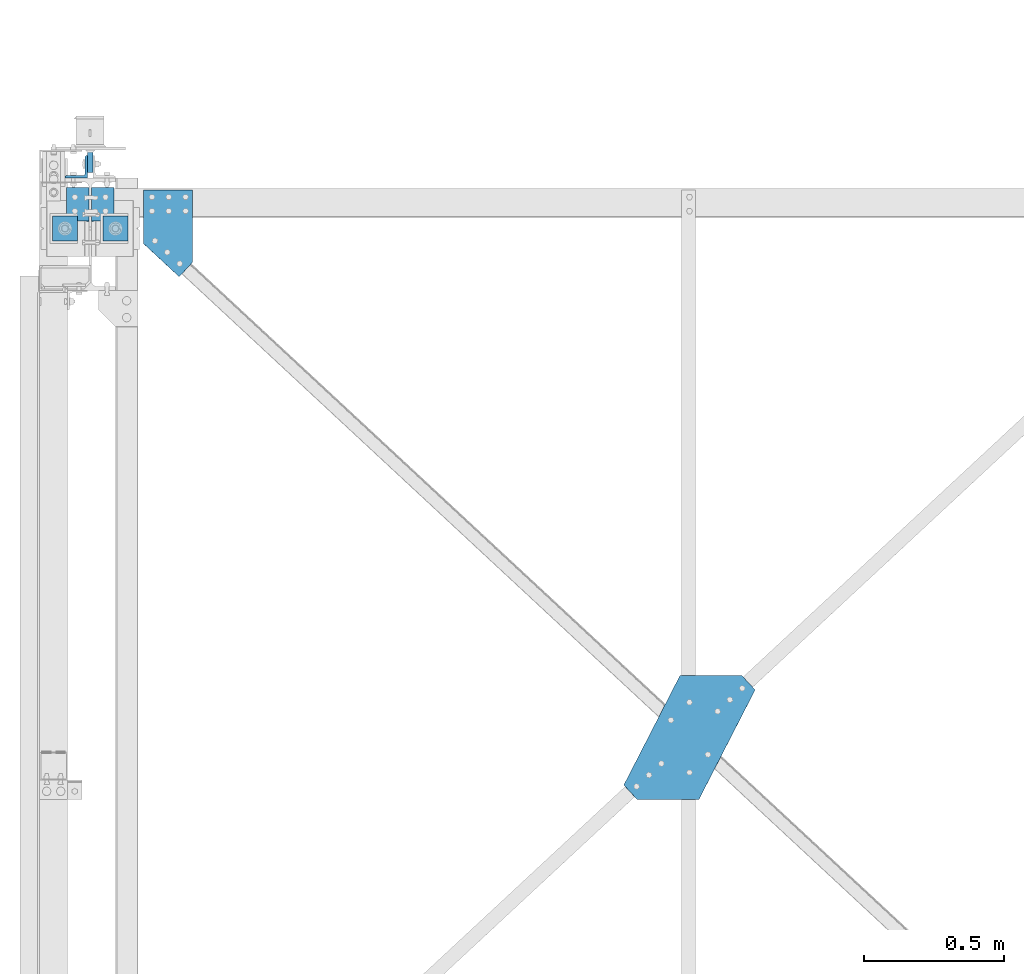
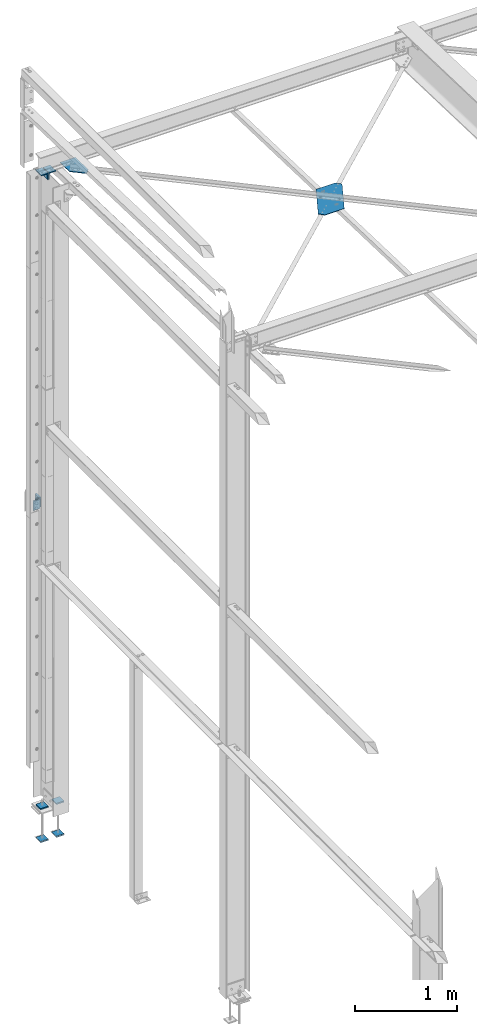
# One storey, part 78 of 496: 10 beams, 7 elements without a shape of their own.
"""IFC2X3 building model written with IfcOpenShell, lengths in millimetres."""

from ifc_helpers import new_model, si_unit, frame, origin_with_axes, origin_2d_with_axis, place, context, subcontext, project, spatial, polyline, rectangle, l_section, outline, extrude, material, type_object, element, aggregate, save


model = new_model("IFC2X3")

# Units and contexts
model_context = context("Model", 3, precision=1e-05, world=origin_with_axes())
body_context = subcontext(model_context, "Body", "Model", "MODEL_VIEW")
ifc_project = project(units=[si_unit("LENGTHUNIT", "METRE", prefix="MILLI"), si_unit("AREAUNIT", "SQUARE_METRE"), si_unit("VOLUMEUNIT", "CUBIC_METRE"), si_unit("MASSUNIT", "GRAM", prefix="KILO"), si_unit("TIMEUNIT", "SECOND"), si_unit("PLANEANGLEUNIT", "RADIAN"), si_unit("SOLIDANGLEUNIT", "STERADIAN"), si_unit("THERMODYNAMICTEMPERATUREUNIT", "DEGREE_CELSIUS"), si_unit("LUMINOUSINTENSITYUNIT", "LUMEN")], contexts=[model_context])

# Site, building, storey
site_placement = place(None, origin_with_axes())
site = spatial("IfcSite", under=ifc_project, at=site_placement, CompositionType="ELEMENT")
building_placement = place(site_placement, origin_with_axes())
building = spatial("IfcBuilding", under=site, at=building_placement, Name="Undefined", CompositionType="ELEMENT")
storey_placement = place(building_placement, origin_with_axes())
storey = spatial("IfcBuildingStorey", under=building, at=storey_placement, Name="Undefined", CompositionType="ELEMENT", Elevation=0.0)

# Assembly, beam
assembly_1_placement = place(storey_placement, origin_with_axes())
assembly_1 = element("IfcElementAssembly", 1, at=assembly_1_placement, inside=storey, AssemblyPlace="NOTDEFINED", PredefinedType="NOTDEFINED")
ifc_material = material(Name="Undefined/S235-E24")
beam_type_1 = type_object("IfcBeamType", PredefinedType="NOTDEFINED")
beam_1_placement = place(assembly_1_placement, frame((-44.4999999998308, 15135.6320367041, 7334.22506224775), z_axis=(0.0, -0.031410887010906, -0.999506556345274), x_axis=(0.0, 0.999506556345274, -0.0314108870109058)))
beam_1 = element("IfcBeam", 2, at=beam_1_placement, type_object=beam_type_1, material=ifc_material, context=body_context, shape_type="SweptSolid", body=[
    extrude(l_section(Depth=80.0, Width=80.0, Thickness=8.0, FilletRadius=10.0, EdgeRadius=5.0, at=origin_2d_with_axis()), frame((120.0, 0.0, 0.0), z_axis=(-1.0, 0.0, 0.0), x_axis=(0.0, -1.0, 0.0)), (0.0, 0.0, 1.0), 120.0),
])
aggregate(assembly_1, [beam_1])

assembly_2_placement = place(storey_placement, origin_with_axes())
assembly_2 = element("IfcElementAssembly", 3, at=assembly_2_placement, inside=storey, AssemblyPlace="NOTDEFINED", PredefinedType="NOTDEFINED")
beam_2_placement = place(assembly_2_placement, frame((44.4999999998308, 15255.5728222173, 7330.45571608796), z_axis=(0.0, -0.031410887010906, -0.999506556345274), x_axis=(0.0, -0.999506556345276, 0.031410887010852)))
beam_2 = element("IfcBeam", 4, at=beam_2_placement, type_object=beam_type_1, material=ifc_material, context=body_context, shape_type="SweptSolid", body=[
    extrude(l_section(Depth=80.0, Width=80.0, Thickness=8.0, FilletRadius=10.0, EdgeRadius=5.0, at=origin_2d_with_axis()), frame((120.0, 0.0, 0.0), z_axis=(-1.0, 0.0, 0.0), x_axis=(0.0, -1.0, 0.0)), (0.0, 0.0, 1.0), 120.0),
])
aggregate(assembly_2, [beam_2])

assembly_3_placement = place(storey_placement, origin_with_axes())
assembly_3 = element("IfcElementAssembly", 5, at=assembly_3_placement, inside=storey, AssemblyPlace="NOTDEFINED", PredefinedType="NOTDEFINED")
beam_3_placement = place(assembly_3_placement, frame((-50.0, 15330.0000024006, 3375.0), z_axis=(-1.0, 0.0, 0.0), x_axis=(0.0, 0.0, -1.0)))
beam_3 = element("IfcBeam", 6, at=beam_3_placement, type_object=beam_type_1, material=ifc_material, context=body_context, shape_type="SweptSolid", body=[
    extrude(l_section(Depth=80.0, Width=80.0, Thickness=8.0, FilletRadius=10.0, EdgeRadius=5.0, at=origin_2d_with_axis()), frame((120.0, 0.0, 0.0), z_axis=(-1.0, 0.0, 0.0), x_axis=(0.0, -1.0, 0.0)), (0.0, 0.0, 1.0), 120.0),
])
aggregate(assembly_3, [beam_3])

assembly_4_placement = place(storey_placement, origin_with_axes())
assembly_4 = element("IfcElementAssembly", 7, at=assembly_4_placement, inside=storey, AssemblyPlace="NOTDEFINED", PredefinedType="NOTDEFINED")
beam_type_2 = type_object("IfcBeamType", PredefinedType="NOTDEFINED")
beam_4_placement = place(assembly_4_placement, frame((2321.30220508621, 13517.6191026885, 7422.09217762643), z_axis=(0.0, 0.031410887010906, 0.999506556345274), x_axis=(-1.0, 0.0, 0.0)))
beam_4 = element("IfcBeam", 8, at=beam_4_placement, type_object=beam_type_2, material=ifc_material, context=body_context, shape_type="SweptSolid", body=[
    extrude(outline(polyline([(0.0, 0.0), (219.999999998594, -9.93168214336038e-10), (420.263031005037, 390.657226561482), (372.604370116365, 441.927673338805), (152.604415892733, 441.927612303649), (-47.6586227425214, 51.2704162588834), (0.0, 0.0)])), frame((0.0, 0.0, -3.0), z_axis=(0.0, 0.0, 1.0), x_axis=(1.0, 0.0, 0.0)), (0.0, 0.0, 1.0), 6.0),
])
aggregate(assembly_4, [beam_4])

assembly_5_placement = place(storey_placement, origin_with_axes())
assembly_5 = element("IfcElementAssembly", 9, at=assembly_5_placement, inside=storey, AssemblyPlace="NOTDEFINED", PredefinedType="NOTDEFINED")
beam_type_3 = type_object("IfcBeamType", PredefinedType="NOTDEFINED")
beam_5_placement = place(assembly_5_placement, frame((316.997693021986, 14938.099610238, 7377.45112643372), z_axis=(0.0, -0.031410887010906, -0.999506556345274), x_axis=(-0.732434513155022, 0.680501525144028, -0.0213859350045245)))
beam_5 = element("IfcBeam", 10, at=beam_5_placement, type_object=beam_type_3, material=ifc_material, context=body_context, shape_type="SweptSolid", body=[
    extrude(outline(polyline([(0.0, 0.0), (173.391189574842, 4.54747350886464e-11), (303.255157470761, 139.705673217641), (175.330810546631, 258.618286132334), (-7.87930366641376e-05, 69.9999999998454), (0.0, 0.0)])), frame((0.0, 0.0, -3.0), z_axis=(0.0, 0.0, 1.0), x_axis=(1.0, 0.0, 0.0)), (0.0, 0.0, 1.0), 6.0),
])
aggregate(assembly_5, [beam_5])

assembly_6_placement = place(storey_placement, origin_with_axes())
assembly_6 = element("IfcElementAssembly", 11, at=assembly_6_placement, inside=storey, AssemblyPlace="NOTDEFINED", PredefinedType="NOTDEFINED")
beam_type_4 = type_object("IfcBeamType", PredefinedType="NOTDEFINED")
beam_6_placement = place(assembly_6_placement, frame((0.0, 15350.0, 3375.0), z_axis=(0.0, -1.0, 0.0), x_axis=(0.0, 0.0, -1.0)))
beam_6 = element("IfcBeam", 12, at=beam_6_placement, type_object=beam_type_4, material=ifc_material, Name="PLAT", context=body_context, shape_type="SweptSolid", body=[
    extrude(rectangle(XDim=20.0, YDim=80.0, at=origin_2d_with_axis()), frame((120.0, 0.0, 0.0), z_axis=(-1.0, 0.0, 0.0), x_axis=(0.0, -1.0, 0.0)), (0.0, 0.0, 1.0), 120.0),
])
aggregate(assembly_6, [beam_6])

# Assembly, beams
assembly_7_placement = place(storey_placement, origin_with_axes())
assembly_7 = element("IfcElementAssembly", 13, at=assembly_7_placement, inside=storey, Name="PS24", AssemblyPlace="NOTDEFINED", PredefinedType="NOTDEFINED")
beam_type_5 = type_object("IfcBeamType", PredefinedType="NOTDEFINED")
beam_7_placement = place(assembly_7_placement, frame((-45.0028495552906, 15064.9999996154, -177.5), z_axis=(0.0, 0.0, 1.0), x_axis=(0.0, 1.0, 0.0)))
beam_7 = element("IfcBeam", 14, at=beam_7_placement, type_object=beam_type_5, material=ifc_material, context=body_context, shape_type="SweptSolid", body=[
    extrude(outline(polyline([(0.0, 0.0), (90.0, 0.0), (90.0, 90.0), (0.0, 90.0), (0.0, 0.0)])), frame((0.0, 0.0, -7.5), z_axis=(0.0, 0.0, 1.0), x_axis=(1.0, 0.0, 0.0)), (0.0, 0.0, 1.0), 15.0),
])
beam_8_placement = place(assembly_7_placement, frame((134.997150444709, 15064.9999996154, -177.5), z_axis=(0.0, 0.0, 1.0), x_axis=(0.0, 1.0, 0.0)))
beam_8 = element("IfcBeam", 15, at=beam_8_placement, type_object=beam_type_5, material=ifc_material, context=body_context, shape_type="SweptSolid", body=[
    extrude(outline(polyline([(0.0, 0.0), (90.0, 0.0), (90.0, 90.0), (0.0, 90.0), (0.0, 0.0)])), frame((0.0, 0.0, -7.5), z_axis=(0.0, 0.0, 1.0), x_axis=(1.0, 0.0, 0.0)), (0.0, 0.0, 1.0), 15.0),
])
beam_9_placement = place(assembly_7_placement, frame((-45.0028495552906, 15064.9999996154, -572.5), z_axis=(0.0, 0.0, 1.0), x_axis=(0.0, 1.0, 0.0)))
beam_9 = element("IfcBeam", 16, at=beam_9_placement, type_object=beam_type_5, material=ifc_material, context=body_context, shape_type="SweptSolid", body=[
    extrude(outline(polyline([(0.0, 0.0), (90.0, 0.0), (90.0, 90.0), (0.0, 90.0), (0.0, 0.0)])), frame((0.0, 0.0, -7.5), z_axis=(0.0, 0.0, 1.0), x_axis=(1.0, 0.0, 0.0)), (0.0, 0.0, 1.0), 15.0),
])
beam_10_placement = place(assembly_7_placement, frame((134.997150444709, 15064.9999996154, -572.5), z_axis=(0.0, 0.0, 1.0), x_axis=(0.0, 1.0, 0.0)))
beam_10 = element("IfcBeam", 17, at=beam_10_placement, type_object=beam_type_5, material=ifc_material, context=body_context, shape_type="SweptSolid", body=[
    extrude(outline(polyline([(0.0, 0.0), (90.0, 0.0), (90.0, 90.0), (0.0, 90.0), (0.0, 0.0)])), frame((0.0, 0.0, -7.5), z_axis=(0.0, 0.0, 1.0), x_axis=(1.0, 0.0, 0.0)), (0.0, 0.0, 1.0), 15.0),
])
aggregate(assembly_7, [beam_7, beam_8, beam_9, beam_10])

save(model, "model.ifc")
